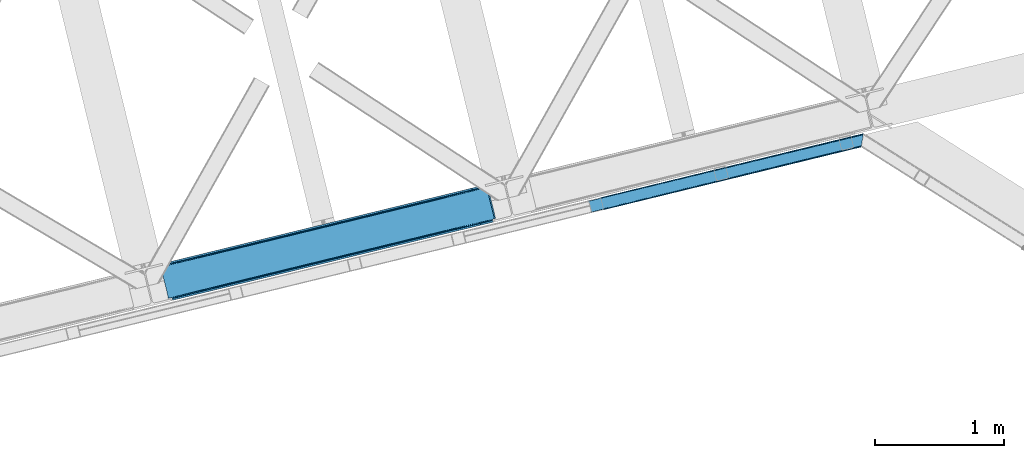
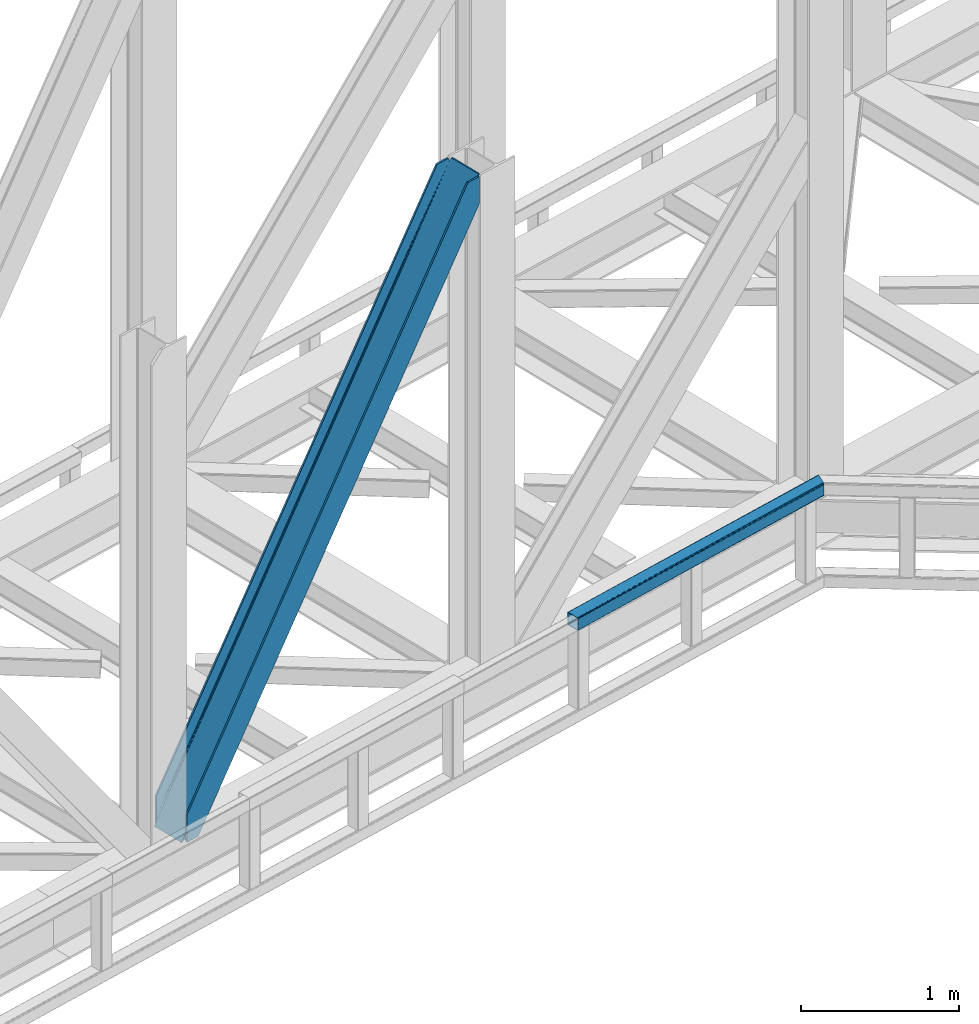
# One storey, part 70 of 93: 1 beam, 1 member.
"""IFC4 building model written with IfcOpenShell, lengths in millimetres."""

from ifc_helpers import new_model, entity, si_unit, converted_unit, derived_unit, direction, frame, origin, place, context, subcontext, project, spatial, triangles, type_object, element, save


model = new_model("IFC4")

# Units and contexts
model_context = context("Model", 3, precision=0.01, world=origin(), true_north=direction((6.12303176911189e-17, 1.0)))
plan_context = context("Plan", 3, precision=0.01, world=origin(), true_north=direction((6.12303176911189e-17, 1.0)))
body_context = subcontext(model_context, "Body", "Model", "MODEL_VIEW")
ifc_project = project(units=[si_unit("LENGTHUNIT", "METRE", prefix="MILLI"), si_unit("AREAUNIT", "SQUARE_METRE"), si_unit("VOLUMEUNIT", "CUBIC_METRE"), converted_unit("PLANEANGLEUNIT", "DEGREE", entity("IfcRatioMeasure", 0.0174532925199433), si_unit("PLANEANGLEUNIT", "RADIAN"), dimensions=[0, 0, 0, 0, 0, 0, 0]), si_unit("MASSUNIT", "GRAM", prefix="KILO"), derived_unit("MASSDENSITYUNIT", [(si_unit("MASSUNIT", "GRAM", prefix="KILO"), 1), (si_unit("LENGTHUNIT", "METRE"), -3)]), derived_unit("MOMENTOFINERTIAUNIT", [(si_unit("LENGTHUNIT", "METRE"), 4)]), si_unit("TIMEUNIT", "SECOND"), si_unit("FREQUENCYUNIT", "HERTZ"), si_unit("THERMODYNAMICTEMPERATUREUNIT", "DEGREE_CELSIUS"), derived_unit("THERMALTRANSMITTANCEUNIT", [(si_unit("MASSUNIT", "GRAM", prefix="KILO"), 1), (si_unit("THERMODYNAMICTEMPERATUREUNIT", "KELVIN"), -1), (si_unit("TIMEUNIT", "SECOND"), -3)]), derived_unit("VOLUMETRICFLOWRATEUNIT", [(si_unit("LENGTHUNIT", "METRE"), 3), (si_unit("TIMEUNIT", "SECOND"), -1)]), derived_unit("MASSFLOWRATEUNIT", [(si_unit("MASSUNIT", "GRAM", prefix="KILO"), 1), (si_unit("TIMEUNIT", "SECOND"), -1)]), derived_unit("ROTATIONALFREQUENCYUNIT", [(si_unit("TIMEUNIT", "SECOND"), -1)]), si_unit("ELECTRICCURRENTUNIT", "AMPERE"), si_unit("ELECTRICVOLTAGEUNIT", "VOLT"), si_unit("POWERUNIT", "WATT"), si_unit("FORCEUNIT", "NEWTON", prefix="KILO"), si_unit("ILLUMINANCEUNIT", "LUX"), si_unit("LUMINOUSFLUXUNIT", "LUMEN"), si_unit("LUMINOUSINTENSITYUNIT", "CANDELA"), derived_unit("USERDEFINED", [(si_unit("MASSUNIT", "GRAM", prefix="KILO"), -1), (si_unit("LENGTHUNIT", "METRE"), -2), (si_unit("TIMEUNIT", "SECOND"), 3), (si_unit("LUMINOUSFLUXUNIT", "LUMEN"), 1)]), derived_unit("LINEARVELOCITYUNIT", [(si_unit("LENGTHUNIT", "METRE"), 1), (si_unit("TIMEUNIT", "SECOND"), -1)]), si_unit("PRESSUREUNIT", "PASCAL"), derived_unit("USERDEFINED", [(si_unit("LENGTHUNIT", "METRE"), -2), (si_unit("MASSUNIT", "GRAM", prefix="KILO"), 1), (si_unit("TIMEUNIT", "SECOND"), -2)]), derived_unit("LINEARFORCEUNIT", [(si_unit("MASSUNIT", "GRAM", prefix="KILO"), 1), (si_unit("LENGTHUNIT", "METRE"), 1), (si_unit("TIMEUNIT", "SECOND"), -2), (si_unit("LENGTHUNIT", "METRE"), -1)]), derived_unit("PLANARFORCEUNIT", [(si_unit("MASSUNIT", "GRAM", prefix="KILO"), 1), (si_unit("LENGTHUNIT", "METRE"), 1), (si_unit("TIMEUNIT", "SECOND"), -2), (si_unit("LENGTHUNIT", "METRE"), -2)])], contexts=[model_context, plan_context])

# Site, building, storey
site_placement = place(None, origin())
site = spatial("IfcSite", under=ifc_project, at=site_placement, CompositionType="ELEMENT")
building_placement = place(site_placement, origin())
building = spatial("IfcBuilding", under=site, at=building_placement, CompositionType="ELEMENT")
storey_placement = place(building_placement, frame((0.0, 0.0, 15900.0)))
storey = spatial("IfcBuildingStorey", under=building, at=storey_placement, CompositionType="ELEMENT", Elevation=15900.0)

# Member
member_type = type_object("IfcMemberType", PredefinedType="BRACE")
member_placement = place(storey_placement, frame((-10911.6037353516, 14812.791192627, 3694.99929199219)))
element("IfcMember", 1, at=member_placement, inside=storey, type_object=member_type, ObjectType="Steel Vertical Brace", PredefinedType="BRACE", context=body_context, shape_type="Tessellation", body=[
    triangles([(2543.71740875244, 876.026760864259, 3910.2403930664), (2543.86042327881, 877.205758666993, 3909.96134033203), (2542.34249267578, 876.83485107422, 3911.00081176758), (2544.23714447021, 869.063232421875, 3911.00081176758), (2527.1870223999, 873.140890502929, 3906.29412231445), (2530.23276672363, 873.883868408204, 3911.00081176758), (2527.1870223999, 873.140890502929, 3884.1908203125), (2518.86892547607, 874.429183959961, 3898.31321411133), (2521.01472473145, 873.423431396484, 3899.16199951172), (2522.8994934082, 872.957180786134, 3877.06799926758), (2518.86892547607, 874.429183959961, 3868.81036376953), (2517.28762664795, 875.594229125976, 3898.850390625), (2517.28762664795, 875.594229125976, 3864.49202270508), (2515.87201538086, 877.455743408203, 3857.29478759765), (2515.70574645996, 877.331332397462, 3901.61533813476), (2513.8953918457, 881.222955322266, 3911.00081176758), (2514.70987701416, 878.98239440918, 3851.39514770508), (2514.17793273926, 880.262548828125, 3838.64708862305), (2514.70987701416, 878.98239440918, 3906.82664794922), (2514.37326965332, 879.734674072266, 3911.00081176758), (2514.17793273926, 880.262548828125, 3698.36960449219), (2513.8953918457, 881.222955322266, 3698.30216674805), (2522.8994934082, 872.957180786134, 3900.77120361328), (1281.82757263184, 579.864605712892, 1933.79126586914), (121.508862304687, 297.023730468751, 0.0), (1706.0627243042, 683.275735473633, 2589.5349609375), (2130.29787597656, 786.688027954102, 3245.28098144531), (857.588351440429, 476.451150512696, 1278.04757080078), (30.7527740478508, 274.901824951172, 0.0), (433.352618408202, 373.040020751954, 622.301550292967), (2511.05370483398, 892.881546020508, 3698.30216674805), (118.429980468749, 309.6543548584, 0.0), (2511.05370483398, 892.881546020508, 3911.00081176758), (2415.21013641357, 869.519018554687, 3911.00081176758), (23.8834259033192, 286.608087158203, 214.700848388671), (23.8834259033192, 286.608087158203, 0.0), (26.9576568603516, 273.658877563477, 0.0), (26.7251129150391, 274.949496459962, 0.0), (26.7251129150391, 274.949496459962, 214.700848388671), (2509.04452514648, 879.011462402344, 3911.00081176758), (2418.28901824951, 856.88839416504, 3911.00081176758), (26.9169616699219, 273.966998291016, 214.633410644528), (1250.04869842529, 572.117404174805, 1964.95680541992), (1676.92729339599, 676.173843383789, 2624.78862304687), (2103.80530700683, 780.230282592775, 3284.61811523437), (823.166033935546, 468.06096496582, 1305.12731323242), (26.9169616699219, 273.966998291016, 74.3536010742173), (396.287438964842, 364.004525756836, 645.295495605467), (25.4356567382802, 266.62907409668, 14.6874755859353), (23.9973724365227, 264.751281738281, 13.8410156249993), (22.5346710205067, 263.467639160157, 35.9326904296868), (25.4356567382802, 266.62907409668, 44.192651367186), (26.2995574951165, 268.389431762696, 14.1502990722656), (26.0007385253903, 268.182467651368, 48.2249633789033), (26.9088226318345, 270.661386108399, 54.6571289062485), (26.9088226318345, 270.661386108399, 11.3853515624978), (27.0332336425781, 272.584524536132, 61.6055419921868), (27.0332336425781, 272.584524536132, 6.17404174804688), (22.5346710205067, 263.467639160157, 12.2294860839829), (18.6395599365223, 261.656121826172, 28.8121948242188), (18.6395599365223, 261.656121826172, 6.70889282226563), (0.0, 257.112213134766, 0.0), (14.3014526367188, 260.598046875, 0.0), (412.365527343749, 356.486380004882, 636.079779052732), (0.597637939452397, 256.057626342774, 0.0), (4.0857971191399, 249.874282836914, 0.0), (2122.62276306152, 766.290435791016, 3274.64197998047), (2534.31856384277, 866.644775390625, 3911.00081176758), (2530.82982330322, 872.828118896485, 3911.00081176758), (2119.88455810547, 772.712136840821, 3275.40239868164), (2109.70145874023, 780.257025146484, 3280.80206909179), (2115.34762573242, 777.617651367187, 3277.56505737305), (407.828594970702, 361.391894531251, 638.242437744138), (402.183590698241, 364.031268310548, 641.479449462888), (415.109545898436, 350.065841674805, 635.319360351561), (829.062185668945, 468.087707519531, 1301.30894165039), (1255.94019927978, 572.144146728517, 1961.14075927734), (1682.81821289062, 676.199423217773, 2620.97025146484), (834.707189941406, 465.447171020509, 1298.07192993164), (1261.58578491211, 569.503610229493, 1957.90374755859), (1688.46903076172, 673.561212158203, 2617.73323974609), (839.248773193358, 460.543981933593, 1295.90927124023), (1266.12736816406, 564.600421142579, 1955.74108886719), (1693.00596313476, 668.656860351563, 2615.57058105469), (841.986978149413, 454.121118164063, 1295.15117797851), (1268.86557312012, 558.177557373047, 1954.98067016601), (1695.74416809082, 662.233996582032, 2614.81248779297), (428.111077880858, 370.35181274414, 626.119921874997), (424.312472534179, 365.409091186524, 629.35693359375), (2119.48225708008, 772.61446838379, 3254.49669799805), (2121.25307922363, 779.057098388672, 3252.33403930664), (423.061386108398, 352.004095458984, 632.280010986327), (14.0084472656235, 252.292739868164, 0.0), (14.2607574462891, 259.388818359375, 0.0), (422.536999511718, 358.966461181641, 631.519592285156), (2125.05110321045, 783.998657226563, 3249.09702758789), (846.772732543945, 462.377590942384, 1287.26328735351), (847.297119140625, 455.415225219727, 1288.02370605469), (1271.00730285644, 565.789883422853, 1943.00930786133), (1271.53168945312, 558.827517700196, 1943.76740112304), (1695.24245452881, 669.201013183594, 2598.75300292969), (1695.76684112549, 662.239810180665, 2599.5110961914), (2120.00199279785, 765.650939941406, 3255.25711669922), (848.548205566405, 468.821383666993, 1285.10062866211), (1272.78277587891, 572.233676147462, 1940.84664916992), (1697.01792755127, 675.644805908203, 2596.59034423828), (852.345648193359, 473.762942504884, 1281.86361694336), (1276.58079986572, 577.175234985352, 1937.60963745117), (1700.81595153808, 680.586364746094, 2593.35333251953), (2589.49949798584, 640.273709106446, 3911.00081176758), (2177.80311584473, 539.91820678711, 3274.64197998047), (1324.04650726318, 331.806491088868, 1954.98067016601), (1750.92452087402, 435.861767578126, 2614.81248779297), (897.167330932616, 227.750051879882, 1295.15117797851), (470.28989868164, 123.693612670899, 635.319360351561), (59.2661499023434, 23.5020538330082, 0.0), (2599.41749725342, 642.691003417969, 3911.00081176758), (2175.18234558105, 539.279873657228, 3255.25711669922), (1750.94719390869, 435.867581176759, 2599.5110961914), (1326.71204223633, 332.456451416016, 1943.76740112304), (902.477471923827, 229.044158935547, 1288.02370605469), (478.2417388916, 125.631866455078, 632.280010986327), (69.1899627685543, 25.9216735839855, 0.0), (59.0138397216797, 16.4071380615242, 0.0), (72.6781219482418, 19.7383300781257, 0.0), (58.9696563720699, 15.1955841064464, 0.0), (73.2711090087887, 18.6825805664066, 0.0), (77.6092163085923, 19.7394927978512, 6.70889282226563), (77.6092163085923, 19.7394927978512, 28.8121948242188), (2589.24718780517, 633.178793334961, 3911.00081176758), (2601.31214904785, 634.919384765626, 3911.00081176758), (2589.2024230957, 631.967239379883, 3911.00081176758), (2602.83007965088, 635.289129638672, 3909.96134033203), (2602.16035308838, 636.270465087891, 3910.2403930664), (2586.15667877197, 631.22426147461, 3906.29412231445), (2586.15667877197, 631.22426147461, 3884.1908203125), (2572.75052032471, 617.663461303711, 3911.00081176758), (2577.81474609375, 619.473815917969, 3911.00081176758), (2577.76707458496, 620.297021484375, 3906.82664794922), (2172.75865631103, 521.571652221681, 3280.80206909179), (2577.89206695557, 622.220159912109, 3901.61533813476), (2578.49668121338, 624.490951538086, 3898.850390625), (2582.26563720703, 629.413906860353, 3900.77120361328), (2178.32750244141, 532.955841064453, 3275.40239868164), (2580.80293579101, 628.130264282227, 3899.15967407226), (2579.36465148926, 626.252471923828, 3898.31321411133), (2176.55668029785, 526.514373779297, 3277.56505737305), (470.809634399413, 116.730084228517, 636.079779052732), (469.038812255858, 110.28861694336, 638.242437744138), (81.9008148193352, 19.9243652343757, 35.9326904296868), (85.931964111327, 18.4523620605469, 44.192651367186), (87.5086120605465, 17.2861541748043, 48.5109924316384), (2167.51188354492, 518.882281494141, 3284.61811523437), (459.994015502929, 102.656524658203, 645.295495605467), (465.240206909179, 105.345895385743, 641.479449462888), (90.6223754882813, 12.6189971923832, 74.3536010742173), (90.0910125732407, 13.8991516113292, 61.6055419921868), (88.9282928466782, 15.4258026123043, 55.7059020996094), (897.691717529297, 220.787686157228, 1295.90927124023), (1324.57089385986, 324.844125366211, 1955.74108886719), (1751.4489074707, 428.900564575195, 2615.57058105469), (895.916244506836, 214.343893432617, 1298.07192993164), (1322.79483947754, 318.400332641602, 1957.90374755859), (1749.67808532715, 422.457934570313, 2617.73323974609), (892.118801879882, 209.402334594726, 1301.30894165039), (1318.99739685059, 313.458773803712, 1961.14075927734), (1745.87599182129, 417.515213012695, 2620.97025146484), (886.871447753905, 206.712963867189, 1305.12731323242), (1313.75469360351, 310.7705657959, 1964.95680541992), (1740.63328857422, 414.827005004883, 2624.78862304687), (90.6223754882813, 12.6189971923832, 214.633410644528), (2481.99501342773, 595.541555786132, 3911.00081176758), (491.167694091797, 111.666439819337, 626.119921874997), (89.094561767577, 15.550213623048, 11.3853515624978), (87.5086120605465, 17.2861541748043, 14.1502990722656), (90.0910125732407, 13.8991516113292, 6.17404174804688), (480.981106567382, 119.210165405273, 631.519592285156), (83.7855834960938, 19.4581146240234, 13.8386901855447), (81.9008148193352, 19.9243652343757, 12.2294860839829), (85.931964111327, 18.4523620605469, 14.6874755859353), (485.521527099609, 114.305813598634, 629.35693359375), (2182.46213378906, 527.953820800782, 3252.33403930664), (2582.26563720703, 629.413906860353, 3877.06799926758), (2579.36465148926, 626.252471923828, 3868.81036376953), (2177.92520141602, 532.858172607423, 3254.49669799805), (2578.79608154297, 624.697915649414, 3864.77572631836), (2577.89206695557, 622.220159912109, 3858.34588623047), (2188.10830078125, 525.313284301757, 3249.09702758789), (2577.76707458496, 620.297021484375, 3851.39514770508), (94.4593505859375, 13.5538238525387, 0.0), (90.5188934326161, 12.9108398437511, 0.0), (497.059194946289, 111.692019653321, 622.301550292967), (2577.88392791748, 618.915710449219, 3838.64708862305), (2194.00387115478, 525.340026855469, 3245.28098144531), (915.403427124023, 215.077569580078, 1281.86361694336), (921.294927978515, 215.10431213379, 1278.04757080078), (1339.63799743652, 318.489862060547, 1937.60963745117), (1345.53414916992, 318.516604614259, 1933.79126586914), (1763.87314910889, 421.902154541016, 2593.35333251953), (1769.76930084228, 421.928897094727, 2589.5349609375), (909.757260131835, 217.718106079103, 1285.10062866211), (1333.9924118042, 321.129235839844, 1940.84664916992), (1758.2269821167, 424.541528320313, 2596.59034423828), (905.215676879881, 222.621295166016, 1287.26328735351), (1329.45082855225, 326.033587646485, 1943.00930786133), (1753.68598022461, 429.444717407227, 2598.75300292969), (90.9049163818345, 11.6585906982418, 0.0), (90.9049163818345, 11.6585906982418, 214.700848388671), (2485.07389526367, 582.910931396485, 3911.00081176758), (93.7466033935543, 0.0, 214.700848388671), (93.7466033935543, 0.0, 0.0), (188.293157958984, 23.046267700196, 0.0), (185.214276123046, 35.6768920898448, 0.0), (2577.88392791748, 618.915710449219, 3698.36960449219), (2578.07577667236, 617.932049560548, 3911.00081176758), (2578.07577667236, 617.932049560548, 3698.30216674805), (2580.91746368408, 606.273458862304, 3698.30216674805), (2580.91746368408, 606.273458862304, 3911.00081176758)], [[1, 2, 3], [3, 4, 1], [3, 5, 6], [5, 3, 2], [7, 5, 2], [8, 9, 10], [10, 11, 8], [8, 11, 12], [13, 12, 11], [14, 15, 12], [16, 17, 18], [19, 15, 14], [16, 20, 19], [19, 17, 16], [14, 17, 19], [18, 21, 22], [22, 16, 18], [13, 14, 12], [9, 23, 10], [5, 7, 23], [10, 23, 7], [21, 24, 25], [26, 21, 27], [21, 26, 24], [21, 18, 27], [28, 25, 24], [29, 25, 30], [28, 30, 25], [31, 22, 32], [22, 21, 25], [25, 32, 22], [16, 22, 33], [31, 33, 22], [34, 31, 35], [31, 34, 33], [32, 35, 31], [36, 35, 32], [32, 29, 36], [29, 32, 25], [37, 38, 29], [38, 36, 29], [38, 39, 35], [35, 36, 38], [16, 33, 40], [20, 16, 40], [34, 40, 33], [34, 41, 40], [39, 34, 35], [41, 39, 42], [39, 41, 34], [41, 42, 43], [43, 44, 41], [44, 45, 41], [40, 41, 45], [46, 43, 42], [42, 47, 48], [48, 46, 42], [49, 50, 51], [51, 52, 49], [53, 49, 52], [52, 54, 53], [55, 56, 53], [57, 58, 55], [56, 55, 58], [38, 37, 58], [58, 47, 38], [39, 38, 47], [47, 42, 39], [57, 47, 58], [54, 55, 53], [50, 59, 51], [51, 59, 60], [61, 60, 59], [60, 61, 62], [63, 62, 61], [64, 65, 66], [67, 68, 69], [70, 8, 12], [70, 69, 23], [23, 9, 70], [9, 8, 70], [69, 5, 23], [69, 6, 5], [71, 72, 12], [12, 15, 71], [19, 40, 45], [45, 71, 19], [73, 74, 57], [57, 55, 73], [64, 51, 60], [60, 65, 64], [60, 62, 65], [64, 73, 54], [54, 52, 64], [52, 51, 64], [55, 54, 73], [74, 48, 47], [47, 57, 74], [19, 20, 40], [15, 19, 71], [12, 72, 70], [69, 70, 67], [66, 75, 64], [76, 46, 48], [48, 74, 76], [77, 43, 46], [46, 76, 77], [78, 44, 43], [43, 77, 78], [71, 45, 78], [44, 78, 45], [79, 76, 73], [74, 73, 76], [80, 77, 79], [76, 79, 77], [81, 78, 80], [77, 80, 78], [72, 71, 78], [78, 81, 72], [82, 79, 64], [73, 64, 79], [83, 80, 79], [79, 82, 83], [84, 81, 80], [80, 83, 84], [70, 72, 81], [81, 84, 70], [85, 82, 64], [64, 75, 85], [86, 83, 82], [82, 85, 86], [87, 84, 86], [83, 86, 84], [67, 70, 87], [84, 87, 70], [88, 89, 53], [53, 56, 88], [30, 88, 58], [58, 29, 30], [90, 10, 7], [7, 1, 90], [7, 2, 1], [90, 91, 13], [13, 11, 90], [11, 10, 90], [92, 93, 94], [95, 49, 53], [95, 94, 61], [61, 59, 95], [59, 50, 95], [50, 49, 95], [94, 63, 61], [53, 89, 95], [94, 95, 92], [14, 91, 17], [14, 13, 91], [91, 96, 17], [18, 17, 96], [96, 27, 18], [58, 37, 29], [56, 58, 88], [97, 98, 92], [92, 95, 97], [99, 100, 98], [98, 97, 99], [101, 102, 100], [100, 99, 101], [90, 103, 102], [102, 101, 90], [1, 4, 90], [103, 90, 4], [104, 97, 95], [95, 89, 104], [105, 99, 104], [97, 104, 99], [106, 101, 105], [99, 105, 101], [91, 90, 101], [101, 106, 91], [107, 104, 88], [89, 88, 104], [108, 105, 107], [104, 107, 105], [109, 106, 105], [105, 108, 109], [96, 91, 106], [106, 109, 96], [28, 107, 88], [88, 30, 28], [24, 108, 107], [107, 28, 24], [26, 109, 24], [108, 24, 109], [27, 96, 26], [109, 26, 96], [110, 68, 67], [87, 111, 67], [112, 113, 87], [112, 87, 86], [67, 111, 110], [87, 113, 111], [85, 114, 112], [112, 86, 85], [85, 75, 115], [66, 116, 75], [85, 115, 114], [75, 116, 115], [4, 117, 118], [119, 103, 118], [100, 102, 119], [100, 119, 120], [118, 103, 4], [119, 102, 103], [98, 100, 120], [120, 121, 98], [121, 122, 92], [123, 93, 122], [121, 92, 98], [122, 93, 92], [66, 116, 93], [116, 124, 125], [124, 126, 125], [62, 65, 63], [65, 66, 94], [93, 116, 123], [127, 125, 126], [125, 123, 116], [93, 94, 66], [94, 63, 65], [128, 129, 126], [126, 127, 128], [110, 130, 131], [130, 132, 131], [6, 69, 3], [3, 69, 68], [110, 117, 68], [68, 117, 4], [110, 131, 117], [4, 3, 68], [133, 134, 131], [117, 131, 134], [131, 135, 133], [131, 132, 135], [135, 136, 133], [137, 138, 139], [140, 141, 142], [140, 139, 141], [130, 143, 135], [144, 145, 143], [144, 146, 145], [143, 130, 144], [135, 132, 130], [144, 147, 142], [142, 146, 144], [111, 144, 130], [148, 115, 116], [149, 150, 151], [148, 124, 129], [129, 149, 148], [129, 150, 149], [124, 126, 129], [151, 152, 149], [116, 124, 148], [130, 110, 111], [142, 147, 140], [137, 139, 153], [140, 153, 139], [154, 155, 156], [157, 156, 155], [157, 149, 158], [157, 155, 149], [152, 158, 149], [159, 114, 148], [115, 148, 114], [160, 112, 159], [114, 159, 112], [161, 113, 112], [112, 160, 161], [144, 111, 113], [113, 161, 144], [162, 159, 148], [148, 149, 162], [163, 160, 162], [159, 162, 160], [164, 161, 163], [160, 163, 161], [147, 144, 164], [161, 164, 144], [165, 162, 149], [149, 155, 165], [166, 163, 162], [162, 165, 166], [167, 164, 163], [163, 166, 167], [140, 147, 167], [164, 167, 147], [168, 165, 154], [155, 154, 165], [169, 166, 168], [165, 168, 166], [170, 167, 169], [166, 169, 167], [153, 140, 167], [167, 170, 153], [169, 171, 172], [172, 153, 170], [153, 172, 137], [170, 169, 172], [171, 169, 168], [168, 154, 171], [156, 171, 154], [173, 174, 175], [173, 176, 174], [177, 178, 179], [177, 180, 178], [179, 128, 177], [128, 125, 177], [128, 127, 125], [177, 181, 175], [175, 180, 177], [122, 177, 125], [182, 183, 184], [185, 134, 136], [136, 182, 185], [136, 183, 182], [134, 133, 136], [184, 186, 182], [182, 186, 187], [187, 188, 182], [187, 189, 188], [190, 191, 176], [173, 192, 176], [190, 176, 192], [189, 193, 188], [194, 188, 193], [125, 123, 122], [175, 181, 173], [195, 196, 173], [192, 173, 196], [197, 198, 195], [196, 195, 198], [199, 200, 198], [198, 197, 199], [188, 194, 200], [200, 199, 188], [201, 195, 173], [173, 181, 201], [202, 197, 195], [195, 201, 202], [203, 199, 197], [197, 202, 203], [182, 188, 199], [199, 203, 182], [204, 201, 177], [181, 177, 201], [205, 202, 201], [201, 204, 205], [206, 203, 205], [202, 205, 203], [185, 182, 206], [203, 206, 182], [121, 204, 122], [177, 122, 204], [120, 205, 121], [204, 121, 205], [119, 206, 205], [205, 120, 119], [118, 185, 206], [206, 119, 118], [117, 134, 185], [185, 118, 117], [180, 151, 150], [150, 179, 178], [175, 158, 152], [175, 152, 151], [151, 180, 175], [207, 157, 176], [176, 157, 158], [158, 174, 176], [207, 208, 156], [171, 156, 208], [156, 157, 207], [176, 191, 207], [175, 174, 158], [150, 178, 180], [179, 150, 129], [129, 128, 179], [208, 172, 171], [209, 208, 210], [208, 209, 172], [211, 210, 207], [208, 207, 210], [212, 190, 211], [190, 212, 213], [191, 207, 190], [207, 211, 190], [198, 214, 213], [194, 214, 200], [194, 193, 214], [198, 200, 214], [213, 196, 198], [192, 196, 213], [213, 190, 192], [146, 184, 183], [183, 143, 145], [142, 186, 184], [142, 187, 186], [184, 146, 142], [215, 189, 139], [187, 141, 139], [139, 189, 187], [214, 193, 216], [215, 216, 193], [193, 189, 215], [139, 138, 215], [142, 141, 187], [183, 145, 146], [136, 135, 143], [143, 183, 136], [217, 209, 210], [217, 218, 209], [210, 212, 217], [211, 212, 210], [215, 138, 137], [218, 215, 137], [137, 209, 218], [209, 137, 172], [214, 216, 213], [216, 217, 212], [212, 213, 216], [218, 217, 216], [216, 215, 218]]),
])

# Beam
beam_type = type_object("IfcBeamType", PredefinedType="BEAM")
beam_placement = place(storey_placement, frame((-7589.58325195313, 15490.7253936768, 3780.00108032226)))
element("IfcBeam", 2, at=beam_placement, inside=storey, type_object=beam_type, ObjectType="Steel Beam", PredefinedType="BEAM", context=body_context, shape_type="Tessellation", body=[
    triangles([(2118.81718139648, 521.003082275391, 99.9985473632842), (2132.86109161377, 606.769940185546, 99.9985473632842), (2.36846008300745, 87.4388488769528, 99.9985473632842), (21.3143966674797, 9.71452331542969, 99.9985473632842), (1.46212005615234, 91.1572265625, 99.2381286621094), (0.693562316893804, 94.3093597412098, 97.0708190917976), (2133.48314666748, 610.56040649414, 98.5335205078154), (0.180221557617188, 96.4150451660153, 93.8268310546882), (2134.10520172119, 614.350872802734, 97.0708190917976), (0.0, 97.1545349121079, 89.9991577148467), (2134.35983734131, 615.920544433593, 93.5338256835967), (2134.61796112061, 617.490216064452, 89.9991577148467), (2134.61796112061, 617.490216064452, 9.9993896484375), (0.0, 97.1545349121079, 9.9993896484375), (2134.35983734131, 615.920544433593, 6.46239624023656), (0.180221557617188, 96.4150451660153, 6.17171630859593), (2134.10520172119, 614.350872802734, 2.92772827148656), (0.693562316893804, 94.3093597412098, 2.92772827148656), (2133.48314666748, 610.56040649414, 1.46270141601781), (1.46212005615234, 91.1572265625, 0.760418701174785), (2132.86109161377, 606.769940185546, 0.0), (2.36846008300745, 87.4388488769528, 0.0), (2118.81718139648, 521.003082275391, 0.0), (21.3143966674797, 9.71452331542969, 0.0), (2118.19512634277, 517.212615966797, 1.46270141601781), (22.2207366943358, 5.99730834960792, 0.760418701174785), (2117.57714080811, 513.423312377929, 2.92772827148656), (22.9892944335934, 2.84517517089807, 2.92772827148656), (2117.31843566895, 511.852478027344, 6.46239624023656), (23.5026351928709, 0.739489746092659, 6.17171630859593), (2117.05973052979, 510.282806396484, 9.9993896484375), (23.6828567504881, 0.0, 9.9993896484375), (2117.05973052979, 510.282806396484, 89.9991577148467), (23.6828567504881, 0.0, 89.9991577148467), (23.5026351928709, 0.739489746092659, 93.8268310546882), (22.9892944335934, 2.84517517089807, 97.0708190917976), (2117.31843566895, 511.852478027344, 93.5338256835967), (22.2207366943358, 5.99730834960792, 99.2381286621094), (2117.57714080811, 513.423312377929, 97.0708190917976), (2118.19512634277, 517.212615966797, 98.5335205078154), (1.87779235839844, 89.4515167236314, 7.92742309570531), (1.36445159912091, 91.5572021484368, 11.1714111328147), (1.18423004150372, 92.2966918945313, 14.9990844726563), (3.55269012451117, 82.5810058593743, 4.99969482421875), (2.64635009765607, 86.2993835449215, 5.76011352539354), (1.87779235839844, 89.4515167236314, 92.0711242675789), (1.18423004150372, 92.2966918945313, 84.9994628906279), (1.36445159912091, 91.5572021484368, 88.8248107910185), (3.55269012451117, 82.5810058593743, 94.9988525390654), (2.64635009765607, 86.2993835449215, 94.2384338378906), (21.8050643920897, 7.70301818847656, 7.92742309570531), (20.130166625976, 14.5723663330064, 4.99969482421875), (21.036506652832, 10.8551513671864, 5.76011352539354), (22.4986267089844, 4.85784301757667, 14.9990844726563), (22.3184051513672, 5.59733276367115, 11.1714111328147), (21.8050643920897, 7.70301818847656, 92.0711242675789), (20.130166625976, 14.5723663330064, 94.9988525390654), (21.036506652832, 10.8551513671864, 94.2384338378906), (22.4986267089844, 4.85784301757667, 84.9994628906279), (22.3184051513672, 5.59733276367115, 88.8248107910185), (2133.22444152832, 608.989572143553, 92.0711242675789), (2133.48314666748, 610.56040649414, 88.5341308593779), (2133.74185180664, 612.130078124999, 84.9994628906279), (2133.74185180664, 612.130078124999, 14.9990844726563), (2131.9849822998, 601.409802246093, 94.9988525390654), (2119.69329071045, 526.363220214844, 94.9988525390654), (2132.60703735352, 605.200268554687, 93.5338256835967), (2133.22444152832, 608.989572143553, 7.92742309570531), (2133.48314666748, 610.56040649414, 11.4644165039063), (2132.60703735352, 605.200268554687, 6.46239624023656), (2131.9849822998, 601.409802246093, 4.99969482421875), (2118.45325012207, 518.783450317382, 92.0711242675789), (2118.19512634277, 517.212615966797, 88.5341308593779), (2119.07588653564, 522.573916625975, 93.5338256835967), (2117.94049072266, 515.642944335938, 84.9994628906279), (2118.45325012207, 518.783450317382, 7.92742309570531), (2119.69329071045, 526.363220214844, 4.99969482421875), (2119.07588653564, 522.573916625975, 6.46239624023656), (2117.94049072266, 515.642944335938, 14.9990844726563), (2118.19512634277, 517.212615966797, 11.4644165039063)], [[1, 2, 3], [3, 4, 1], [5, 3, 2], [6, 5, 7], [8, 6, 9], [10, 8, 11], [11, 12, 10], [9, 11, 8], [7, 9, 6], [2, 7, 5], [13, 14, 12], [10, 12, 14], [14, 13, 15], [16, 15, 17], [18, 17, 19], [20, 19, 21], [21, 22, 20], [19, 20, 18], [17, 18, 16], [15, 16, 14], [21, 23, 22], [24, 22, 23], [24, 23, 25], [26, 25, 27], [28, 27, 29], [30, 29, 31], [31, 32, 30], [29, 30, 28], [27, 28, 26], [25, 26, 24], [32, 31, 33], [33, 34, 32], [35, 34, 33], [36, 35, 37], [38, 36, 39], [4, 38, 40], [40, 1, 4], [39, 40, 38], [37, 39, 36], [33, 37, 35], [16, 41, 42], [43, 10, 14], [16, 42, 14], [16, 18, 41], [42, 43, 14], [41, 18, 20], [44, 22, 24], [22, 45, 20], [45, 22, 44], [45, 41, 20], [8, 46, 6], [47, 10, 43], [10, 48, 8], [48, 10, 47], [8, 48, 46], [3, 49, 4], [5, 6, 46], [46, 50, 5], [50, 49, 3], [3, 5, 50], [51, 26, 28], [24, 52, 44], [24, 53, 52], [53, 24, 26], [51, 53, 26], [54, 32, 34], [30, 55, 51], [28, 30, 51], [55, 30, 32], [54, 55, 32], [38, 56, 36], [4, 49, 57], [57, 58, 4], [58, 56, 38], [38, 4, 58], [35, 36, 56], [34, 59, 54], [60, 34, 35], [34, 60, 59], [60, 35, 56], [11, 61, 62], [63, 64, 12], [12, 11, 62], [9, 61, 11], [62, 63, 12], [61, 9, 7], [65, 2, 66], [2, 67, 7], [67, 2, 65], [67, 61, 7], [68, 19, 17], [64, 13, 12], [69, 15, 13], [69, 13, 64], [17, 15, 68], [19, 70, 21], [15, 69, 68], [19, 68, 70], [21, 71, 23], [71, 21, 70], [72, 37, 73], [1, 66, 2], [1, 40, 74], [1, 74, 66], [74, 40, 72], [73, 33, 75], [37, 72, 39], [39, 72, 40], [75, 33, 31], [37, 33, 73], [25, 76, 27], [23, 71, 77], [78, 23, 77], [25, 78, 76], [25, 23, 78], [29, 27, 76], [31, 79, 75], [80, 31, 29], [31, 80, 79], [80, 29, 76], [65, 66, 49], [57, 49, 66], [47, 63, 62], [48, 62, 61], [46, 61, 67], [50, 67, 65], [65, 49, 50], [67, 50, 46], [61, 46, 48], [62, 48, 47], [43, 64, 63], [63, 47, 43], [45, 44, 71], [41, 45, 70], [42, 41, 68], [43, 42, 69], [69, 64, 43], [68, 69, 42], [70, 68, 41], [71, 70, 45], [77, 71, 44], [44, 52, 77], [55, 54, 79], [51, 55, 80], [53, 51, 76], [52, 53, 78], [78, 77, 52], [76, 78, 53], [80, 76, 51], [79, 80, 55], [79, 54, 75], [59, 75, 54], [57, 66, 74], [58, 74, 72], [56, 72, 73], [60, 73, 75], [75, 59, 60], [73, 60, 56], [72, 56, 58], [74, 58, 57]]),
])

save(model, "model.ifc")
